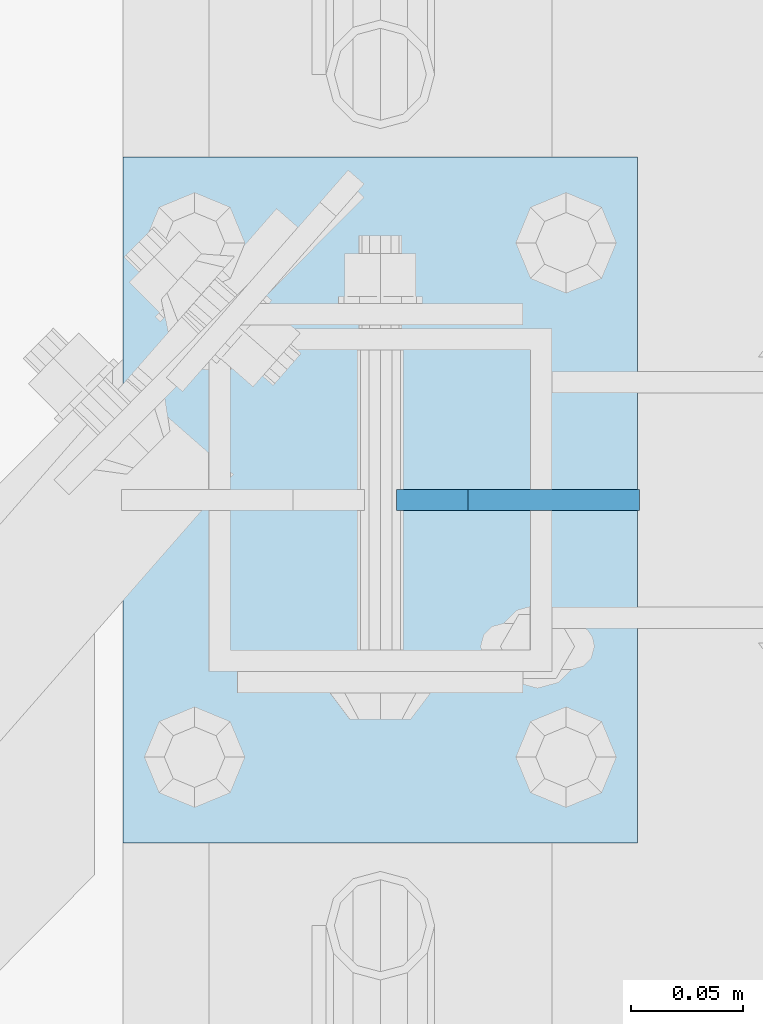
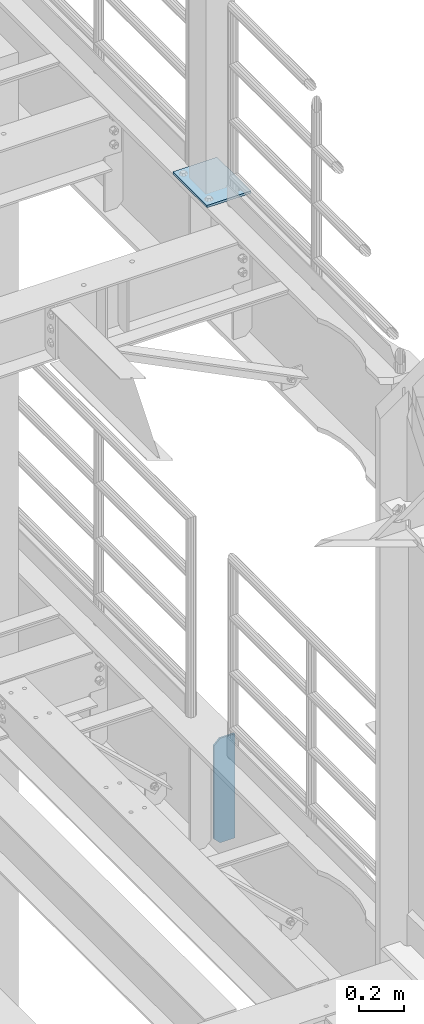
# One storey, part 1678 of 1876: 2 plates, 2 elements without a shape of their own.
"""IFC2X3 building model written with IfcOpenShell, lengths in millimetres."""

from ifc_helpers import new_model, si_unit, frame, origin_with_axes, place, context, subcontext, project, spatial, faceted_brep, material, type_object, element, aggregate, save


model = new_model("IFC2X3")

# Units and contexts
model_context = context("Model", 3, precision=1e-05, world=origin_with_axes())
body_context = subcontext(model_context, "Body", "Model", "MODEL_VIEW")
ifc_project = project(units=[si_unit("LENGTHUNIT", "METRE", prefix="MILLI"), si_unit("AREAUNIT", "SQUARE_METRE"), si_unit("VOLUMEUNIT", "CUBIC_METRE"), si_unit("MASSUNIT", "GRAM", prefix="KILO"), si_unit("TIMEUNIT", "SECOND"), si_unit("PLANEANGLEUNIT", "RADIAN"), si_unit("SOLIDANGLEUNIT", "STERADIAN"), si_unit("THERMODYNAMICTEMPERATUREUNIT", "DEGREE_CELSIUS"), si_unit("LUMINOUSINTENSITYUNIT", "LUMEN")], contexts=[model_context])

# Site, building, storey
site_placement = place(None, origin_with_axes())
site = spatial("IfcSite", under=ifc_project, at=site_placement, CompositionType="ELEMENT")
building_placement = place(site_placement, origin_with_axes())
building = spatial("IfcBuilding", under=site, at=building_placement, Name="Undefined", CompositionType="ELEMENT")
storey_placement = place(building_placement, origin_with_axes())
storey = spatial("IfcBuildingStorey", under=building, at=storey_placement, Name="Undefined", CompositionType="ELEMENT", Elevation=0.0)

# Assembly, plate
assembly_1_placement = place(storey_placement, origin_with_axes())
assembly_1 = element("IfcElementAssembly", 1, at=assembly_1_placement, inside=storey, Name="BEAM", AssemblyPlace="NOTDEFINED", PredefinedType="RIGID_FRAME")
ifc_material = material(Name="STEEL/A36")
plate_type_1 = type_object("IfcPlateType", PredefinedType="NOTDEFINED")
plate_1_placement = place(assembly_1_placement, frame((7735.09375, 3556.0, 4533.9), z_axis=(0.0, 0.0, 1.0), x_axis=(-1.0, 0.0, 0.0)))
plate_1 = element("IfcPlate", 2, at=plate_1_placement, type_object=plate_type_1, material=ifc_material, Name="PLATE", context=body_context, shape_type="Brep", body=[
    faceted_brep([(0.0, -4.76249999999982, 0.0), (0.0, -4.76249999999982, 571.5), (0.0, 4.76249999999982, 571.5), (0.0, 4.76249999999982, 0.0), (76.1999969482422, -4.76249999999982, 571.5), (76.1999969482422, 4.76249999999982, 571.5), (107.949996948242, -4.76249999999982, 539.75), (107.949996948242, 4.76249999999982, 539.75), (107.949996948242, -4.76249999999982, 31.75), (107.949996948242, 4.76249999999982, 31.75), (76.1999969482422, -4.76250000000073, 0.0), (76.1999969482422, 4.76250000000073, 0.0)], [[[0, 1, 2, 3]], [[1, 4, 5, 2]], [[4, 6, 7, 5]], [[6, 8, 9, 7]], [[8, 10, 11, 9]], [[10, 0, 3, 11]], [[5, 7, 9, 11, 3, 2]], [[10, 8, 6, 4, 1, 0]]]),
])
aggregate(assembly_1, [plate_1])

assembly_2_placement = place(storey_placement, origin_with_axes())
assembly_2 = element("IfcElementAssembly", 3, at=assembly_2_placement, inside=storey, Name="BEAM", AssemblyPlace="NOTDEFINED", PredefinedType="RIGID_FRAME")
plate_type_2 = type_object("IfcPlateType", PredefinedType="NOTDEFINED")
plate_2_placement = place(assembly_2_placement, frame((7505.7, 3403.6, 8159.75), z_axis=(0.0, 1.0, 0.0), x_axis=(1.0, 0.0, 0.0)))
plate_2 = element("IfcPlate", 4, at=plate_2_placement, type_object=plate_type_2, material=ifc_material, Name="PLATE", context=body_context, shape_type="Brep", body=[
    faceted_brep([(0.0, -6.35000000000036, 0.0), (0.0, -6.35000000000036, 304.799987792969), (0.0, 6.35000000000036, 304.799987792969), (0.0, 6.35000000000036, 0.0), (228.600006103516, -6.34999999999854, 304.799987792969), (228.600006103516, 6.34999999999854, 304.799987792969), (228.600006103516, -6.34999999999854, 0.0), (228.600006103516, 6.34999999999854, 0.0)], [[[0, 1, 2, 3]], [[1, 4, 5, 2]], [[4, 6, 7, 5]], [[6, 0, 3, 7]], [[5, 7, 3, 2]], [[6, 4, 1, 0]]]),
])
aggregate(assembly_2, [plate_2])

save(model, "model.ifc")
